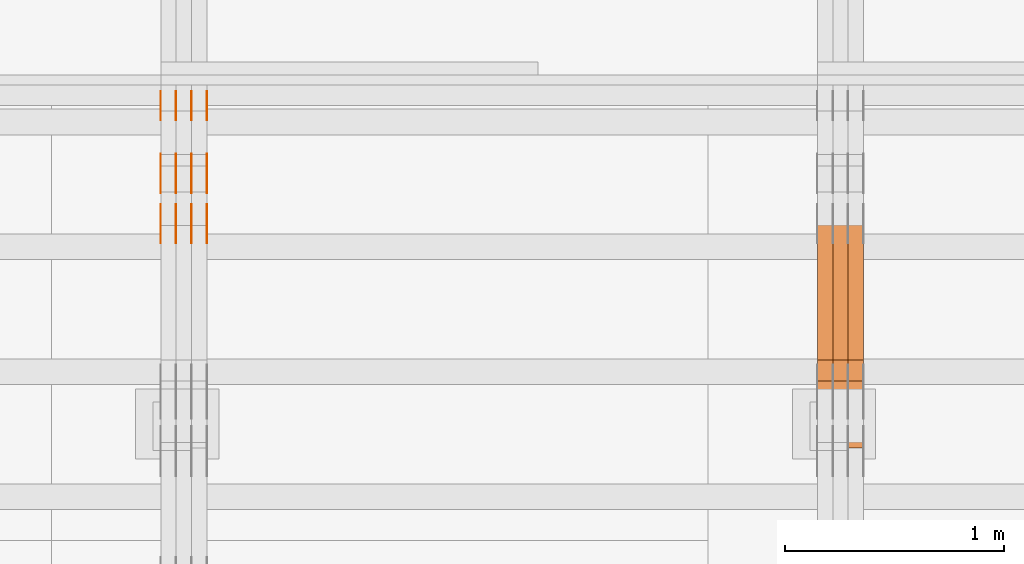
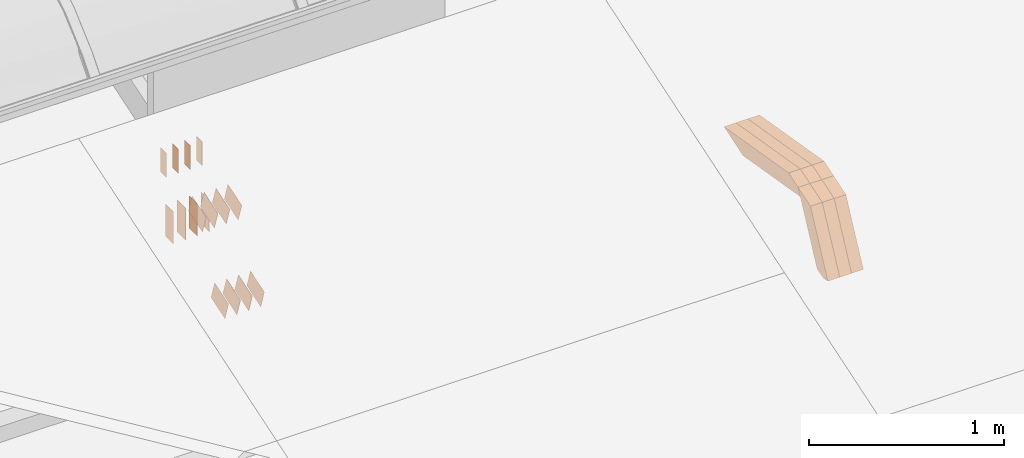
# One storey, part 96 of 385: 30 proxies.
"""IFC2X3 building model written with IfcOpenShell, lengths in millimetres."""

import ifcopenshell
import ifcopenshell.guid

model = None  # the IFC model being written
_history = None  # IfcOwnerHistory: only IFC2X3 demands one
_inside = {}  # id of a spatial element -> (the spatial element, [elements in it])
_under = {}  # id of a project, library or spatial element -> (it, [spatial elements below it])
_declared = {}  # id of a project -> (the project, [libraries it declares])
_typed = {}  # id of a type object -> (the type object, [elements of that type])
_made_of = {}  # id of a material, layer set ... -> (it, [elements and type objects made of it])


def new_model(schema):
    """Start an empty IFC model of exactly this schema.

    Asked for "IFC4X3", IfcOpenShell would pick the latest addendum, in which some entities
    have other attributes; the version numbers below select the first issue.
    IFC2X3 requires an IfcOwnerHistory on every rooted entity: one is made here for all.
    """
    global model, _history
    if schema == "IFC4X3":
        model = ifcopenshell.file(schema_version=(4, 3, 0, 0))
    else:
        model = ifcopenshell.file(schema=schema)
    _inside.clear()
    _under.clear()
    _declared.clear()
    _typed.clear()
    _made_of.clear()
    _history = None
    if model.schema == "IFC2X3":
        org = make("IfcOrganization", Name="unknown")
        user = make(
            "IfcPersonAndOrganization",
            ThePerson=make("IfcPerson", FamilyName="unknown"),
            TheOrganization=org,
        )
        app = make(
            "IfcApplication",
            ApplicationDeveloper=org,
            Version="unknown",
            ApplicationFullName="unknown",
            ApplicationIdentifier="unknown",
        )
        _history = make(
            "IfcOwnerHistory",
            OwningUser=user,
            OwningApplication=app,
            ChangeAction="ADDED",
            CreationDate=0,
        )
    return model


def make(cls, **values):
    """One entity of the class cls with the attributes given. An attribute that is None is left unset."""
    return model.create_entity(
        cls, **{name: value for name, value in values.items() if value is not None}
    )


def entity(cls, *values):
    """Any entity or typed value of the class cls, its attributes in the order of the schema. None: left unset."""
    e = model.create_entity(cls)
    for i, value in enumerate(values):
        if value is not None:
            e[i] = value
    return e


def rooted(cls, **values):
    """An entity with a GlobalId (a new one), such as an element, a storey or a relation."""
    return make(cls, GlobalId=ifcopenshell.guid.new(), OwnerHistory=_history, **values)


def si_unit(unit_type, name, prefix=None):
    """IfcSIUnit, for example si_unit("LENGTHUNIT", "METRE", prefix="MILLI")."""
    return make("IfcSIUnit", UnitType=unit_type, Prefix=prefix, Name=name)


def converted_unit(unit_type, name, factor, base, dimensions=None, offset=None):
    """IfcConversionBasedUnit, such as the inch: factor (a typed value) times the base unit."""
    return make(
        "IfcConversionBasedUnit"
        if offset is None
        else "IfcConversionBasedUnitWithOffset",
        ConversionOffset=offset,
        Dimensions=None
        if dimensions is None
        else entity("IfcDimensionalExponents", *dimensions),
        UnitType=unit_type,
        Name=name,
        ConversionFactor=make(
            "IfcMeasureWithUnit", ValueComponent=factor, UnitComponent=base
        ),
    )


def derived_unit(unit_type, elements):
    """IfcDerivedUnit: a product of units, each with its exponent."""
    return make(
        "IfcDerivedUnit",
        Elements=[
            make("IfcDerivedUnitElement", Unit=unit, Exponent=power)
            for unit, power in elements
        ],
        UnitType=unit_type,
    )


def assignment(units):
    """IfcUnitAssignment: the units of a project."""
    return None if units is None else make("IfcUnitAssignment", Units=units)


def point(xyz):
    """IfcCartesianPoint."""
    return None if xyz is None else make("IfcCartesianPoint", Coordinates=xyz)


def direction(xyz):
    """IfcDirection."""
    return None if xyz is None else make("IfcDirection", DirectionRatios=xyz)


def frame(location, z_axis=None, x_axis=None):
    """IfcAxis2Placement3D, a coordinate frame: its origin and axes. An axis left out is left unset."""
    return make(
        "IfcAxis2Placement3D",
        Location=point(location),
        Axis=direction(z_axis),
        RefDirection=direction(x_axis),
    )


def frame_2d(location, x_axis=None):
    """IfcAxis2Placement2D, a coordinate frame in the plane: its origin and x axis."""
    return make(
        "IfcAxis2Placement2D", Location=point(location), RefDirection=direction(x_axis)
    )


def origin():
    """The frame at (0, 0, 0) with its axes left unset."""
    return frame((0.0, 0.0, 0.0))


def origin_2d_with_axis():
    """The frame at (0, 0) in the plane with the x axis (1, 0) written out."""
    return frame_2d((0.0, 0.0), x_axis=(1.0, 0.0))


def place(relative_to, where):
    """IfcLocalPlacement: puts the frame where relative to a parent placement (None: the world)."""
    return make(
        "IfcLocalPlacement", PlacementRelTo=relative_to, RelativePlacement=where
    )


def context(
    kind, dimensions, precision=None, world=None, true_north=None, identifier=None
):
    """IfcGeometricRepresentationContext, for example the 3D "Model" context."""
    return make(
        "IfcGeometricRepresentationContext",
        ContextIdentifier=identifier,
        ContextType=kind,
        CoordinateSpaceDimension=dimensions,
        Precision=precision,
        WorldCoordinateSystem=world,
        TrueNorth=true_north,
    )


def subcontext(parent, identifier, kind, view, scale=None):
    """IfcGeometricRepresentationSubContext, for example "Body" below "Model"."""
    return make(
        "IfcGeometricRepresentationSubContext",
        ContextIdentifier=identifier,
        ContextType=kind,
        ParentContext=parent,
        TargetScale=scale,
        TargetView=view,
    )


def project(units=None, contexts=None):
    """IfcProject with its units and contexts."""
    return rooted(
        "IfcProject",
        Name="project",
        RepresentationContexts=contexts,
        UnitsInContext=assignment(units),
    )


def spatial(cls, under=None, at=None, **own):
    """A site, building, storey or space (cls), placed at a placement, below another one or the project."""
    s = rooted(cls, ObjectPlacement=at, **own)
    if under is not None:
        _under.setdefault(under.id(), (under, []))[1].append(s)
    return s


def polyline(points):
    """IfcPolyline through the points."""
    return make("IfcPolyline", Points=[point(p) for p in points])


def profile(cls, at=None, kind="AREA", **sizes):
    """A parametric profile (cls). Its sizes go by their IFC names, for example OverallWidth=200.0."""
    return make(cls, ProfileType=kind, Position=at, **sizes)


def rectangle(**sizes):
    """IfcRectangleProfileDef."""
    return profile("IfcRectangleProfileDef", **sizes)


def outline(outer, holes=None, kind="AREA"):
    """IfcArbitraryClosedProfileDef: a profile drawn as a closed curve; with holes, ...WithVoids."""
    if holes is None:
        return make("IfcArbitraryClosedProfileDef", ProfileType=kind, OuterCurve=outer)
    return make(
        "IfcArbitraryProfileDefWithVoids",
        ProfileType=kind,
        OuterCurve=outer,
        InnerCurves=holes,
    )


def extrude(swept, where, along, depth):
    """IfcExtrudedAreaSolid: the profile swept, set in the frame where, extruded along a direction by depth."""
    return make(
        "IfcExtrudedAreaSolid",
        SweptArea=swept,
        Position=where,
        ExtrudedDirection=direction(along),
        Depth=depth,
    )


def shape(context_of_items, identifier, shape_type, items):
    """IfcShapeRepresentation: the items that make up one representation, for example the "Body"."""
    return make(
        "IfcShapeRepresentation",
        ContextOfItems=context_of_items,
        RepresentationIdentifier=identifier,
        RepresentationType=shape_type,
        Items=items,
    )


def source(mapping_origin, context_of_items, identifier, shape_type, items):
    """IfcRepresentationMap: a shape defined once, which mapped items show again and again."""
    return make(
        "IfcRepresentationMap",
        MappingOrigin=mapping_origin,
        MappedRepresentation=shape(context_of_items, identifier, shape_type, items),
    )


def transform(
    local_origin,
    x_axis=None,
    y_axis=None,
    z_axis=None,
    scale=None,
    scale2=None,
    scale3=None,
    uniform=True,
):
    """IfcCartesianTransformationOperator3D, or its non-uniform kind. x_axis, y_axis, z_axis: its Axis1, 2, 3."""
    if uniform:
        return make(
            "IfcCartesianTransformationOperator3D",
            Axis1=direction(x_axis),
            Axis2=direction(y_axis),
            LocalOrigin=point(local_origin),
            Scale=scale,
            Axis3=direction(z_axis),
        )
    return make(
        "IfcCartesianTransformationOperator3DnonUniform",
        Axis1=direction(x_axis),
        Axis2=direction(y_axis),
        LocalOrigin=point(local_origin),
        Scale=scale,
        Axis3=direction(z_axis),
        Scale2=scale2,
        Scale3=scale3,
    )


def mapped(mapping_source, mapping_target):
    """IfcMappedItem: shows the shape of a source again, moved by a transform."""
    return make(
        "IfcMappedItem", MappingSource=mapping_source, MappingTarget=mapping_target
    )


def material(Name=None, Category=None):
    """IfcMaterial."""
    return make("IfcMaterial", Name=Name, Category=Category)


def made_of(thing, what):
    """Note that an element or type object is made of a material, layer set ...; save() writes the relation."""
    if what is not None:
        _made_of.setdefault(what.id(), (what, []))[1].append(thing)
    return thing


def type_object(cls, material=None, **own):
    """A type object (cls), such as IfcWallType, which elements share."""
    return made_of(rooted(cls, **own), material)


def type_shapes(of_type, sources):
    """Give a type object the sources (RepresentationMaps) that its elements show as mapped items."""
    of_type.RepresentationMaps = sources


def element(
    cls,
    number,
    at=None,
    inside=None,
    cuts=None,
    type_object=None,
    material=None,
    context=None,
    identifier="Body",
    shape_type=None,
    held_by="IfcProductDefinitionShape",
    body=None,
    shapes=None,
    **own,
):
    """One element of the class cls, such as IfcWall. Its Tag is "e" and its number.

    at: its placement. inside: the storey or other place that contains it. cuts: it is an
    opening in that element (IfcRelVoidsElement). A single representation is given by context,
    identifier, shape_type and body (its items); several are given by shapes. held_by: the class
    of the entity that holds the representations. save() writes the other relations.
    """
    e = rooted(cls, Tag="e%d" % number, ObjectPlacement=at, **own)
    if body is not None:
        shapes = [shape(context, identifier, shape_type, body)]
    if shapes is not None:
        e.Representation = make(held_by, Representations=shapes)
    if inside is not None:
        _inside.setdefault(inside.id(), (inside, []))[1].append(e)
    if cuts is not None:
        rooted(
            "IfcRelVoidsElement", RelatingBuildingElement=cuts, RelatedOpeningElement=e
        )
    if type_object is not None:
        _typed.setdefault(type_object.id(), (type_object, []))[1].append(e)
    return made_of(e, material)


def aggregate(whole, parts):
    """IfcRelAggregates: a whole, such as a stair, and the parts it consists of."""
    return rooted("IfcRelAggregates", RelatingObject=whole, RelatedObjects=parts)


def save(model, path):
    """Write the relations noted so far, then the file.

    IfcRelAggregates (storeys below a building ...), IfcRelContainedInSpatialStructure (elements
    in a storey), IfcRelDefinesByType, IfcRelAssociatesMaterial and IfcRelDeclares: one each for
    every whole, place, type object, material and project.
    """
    for whole, parts in _under.values():
        aggregate(whole, parts)
    for where, things in _inside.values():
        rooted(
            "IfcRelContainedInSpatialStructure",
            RelatedElements=things,
            RelatingStructure=where,
        )
    for kind, things in _typed.values():
        rooted("IfcRelDefinesByType", RelatedObjects=things, RelatingType=kind)
    for what, things in _made_of.values():
        rooted("IfcRelAssociatesMaterial", RelatedObjects=things, RelatingMaterial=what)
    for by, libraries in _declared.values():
        rooted("IfcRelDeclares", RelatingContext=by, RelatedDefinitions=libraries)
    model.write(path)


model = new_model("IFC2X3")

# Units and contexts
model_context = context("Model", 3, precision=0.01, world=origin(), true_north=direction((6.12303176911189e-17, 1.0)))
body_context = subcontext(model_context, "Body", "Model", "MODEL_VIEW")
ifc_project = project(units=[si_unit("LENGTHUNIT", "METRE", prefix="MILLI"), si_unit("AREAUNIT", "SQUARE_METRE"), si_unit("VOLUMEUNIT", "CUBIC_METRE"), converted_unit("PLANEANGLEUNIT", "DEGREE", entity("IfcRatioMeasure", 0.0174532925199433), si_unit("PLANEANGLEUNIT", "RADIAN"), dimensions=[0, 0, 0, 0, 0, 0, 0]), si_unit("MASSUNIT", "GRAM", prefix="KILO"), derived_unit("MASSDENSITYUNIT", [(si_unit("MASSUNIT", "GRAM", prefix="KILO"), 1), (si_unit("LENGTHUNIT", "METRE"), -3)]), si_unit("TIMEUNIT", "SECOND"), si_unit("FREQUENCYUNIT", "HERTZ"), si_unit("THERMODYNAMICTEMPERATUREUNIT", "DEGREE_CELSIUS"), derived_unit("THERMALTRANSMITTANCEUNIT", [(si_unit("MASSUNIT", "GRAM", prefix="KILO"), 1), (si_unit("THERMODYNAMICTEMPERATUREUNIT", "KELVIN"), -1), (si_unit("TIMEUNIT", "SECOND"), -3)]), derived_unit("VOLUMETRICFLOWRATEUNIT", [(si_unit("LENGTHUNIT", "METRE"), 3), (si_unit("TIMEUNIT", "SECOND"), -1)]), si_unit("ELECTRICCURRENTUNIT", "AMPERE"), si_unit("ELECTRICVOLTAGEUNIT", "VOLT"), si_unit("POWERUNIT", "WATT"), si_unit("FORCEUNIT", "NEWTON", prefix="KILO"), si_unit("ILLUMINANCEUNIT", "LUX"), si_unit("LUMINOUSFLUXUNIT", "LUMEN"), si_unit("LUMINOUSINTENSITYUNIT", "CANDELA"), derived_unit("USERDEFINED", [(si_unit("MASSUNIT", "GRAM", prefix="KILO"), -1), (si_unit("LENGTHUNIT", "METRE"), -2), (si_unit("TIMEUNIT", "SECOND"), 3), (si_unit("LUMINOUSFLUXUNIT", "LUMEN"), 1)]), derived_unit("LINEARVELOCITYUNIT", [(si_unit("LENGTHUNIT", "METRE"), 1), (si_unit("TIMEUNIT", "SECOND"), -1)]), si_unit("PRESSUREUNIT", "PASCAL"), derived_unit("USERDEFINED", [(si_unit("LENGTHUNIT", "METRE"), -2), (si_unit("MASSUNIT", "GRAM", prefix="KILO"), 1), (si_unit("TIMEUNIT", "SECOND"), -2)])], contexts=[model_context])

# Site, building, storey
site_placement = place(None, origin())
site = spatial("IfcSite", under=ifc_project, at=site_placement, CompositionType="ELEMENT")
building_placement = place(site_placement, origin())
building = spatial("IfcBuilding", under=site, at=building_placement, CompositionType="ELEMENT")
storey_placement = place(building_placement, origin())
storey = spatial("IfcBuildingStorey", under=building, at=storey_placement, Name="Default", CompositionType="ELEMENT", Elevation=0.0)

# Proxies
ifc_material_1 = material(Name="IfcSurfaceStyle #189376")
building_element_proxy_type_1 = type_object("IfcBuildingElementProxyType", Name="T1-W7 189374", PredefinedType="NOTDEFINED", material=ifc_material_1)
shared_shape_1 = source(origin(), body_context, "Body", "SweptSolid", [
    extrude(outline(polyline([(-296.174043820986, -47.5000676566704), (297.841254477443, -47.5000676566704), (283.518570346415, -7.10254316533821e-06), (192.674144473719, 47.500071207942), (-477.859925476591, 47.500071207942), (-296.174043820986, -47.5000676566704)])), frame((297.841254477443, 47.5000816097442, 0.0), z_axis=(0.0, 0.0, 1.0), x_axis=(-1.0, 0.0, 0.0)), (0.0, 0.0, 1.0), 70.0),
])
type_shapes(building_element_proxy_type_1, [shared_shape_1])
proxy_1_placement = place(building_placement, frame((15385.0, 12419.2991208897, 3526.2136755972), z_axis=(-1.0, 0.0, 0.0), x_axis=(0.0, 0.985983815111804, -0.166840991178939)))
element("IfcBuildingElementProxy", 1, at=proxy_1_placement, inside=storey, type_object=building_element_proxy_type_1, material=ifc_material_1, Name="T1-W7", context=body_context, shape_type="MappedRepresentation", body=[
    mapped(shared_shape_1, transform((0.0, 0.0, 0.0), scale=1.0)),
])
ifc_material_2 = material(Name="IfcSurfaceStyle #189310")
building_element_proxy_type_2 = type_object("IfcBuildingElementProxyType", Name="T1-W7 189308", PredefinedType="NOTDEFINED", material=ifc_material_2)
shared_shape_2 = source(origin(), body_context, "Body", "SweptSolid", [
    extrude(outline(polyline([(-296.174043820986, -47.5000676566704), (297.841254477443, -47.5000676566704), (283.518570346415, -7.10254316533821e-06), (192.674144473719, 47.500071207942), (-477.859925476591, 47.500071207942), (-296.174043820986, -47.5000676566704)])), frame((297.841254477443, 47.5000816097442, 0.0), z_axis=(0.0, 0.0, 1.0), x_axis=(-1.0, 0.0, 0.0)), (0.0, 0.0, 1.0), 70.0),
])
type_shapes(building_element_proxy_type_2, [shared_shape_2])
proxy_2_placement = place(building_placement, frame((15315.0, 12419.2991208897, 3526.2136755972), z_axis=(-1.0, 0.0, 0.0), x_axis=(0.0, 0.985983815111804, -0.166840991178939)))
element("IfcBuildingElementProxy", 2, at=proxy_2_placement, inside=storey, type_object=building_element_proxy_type_2, material=ifc_material_2, Name="T1-W7", context=body_context, shape_type="MappedRepresentation", body=[
    mapped(shared_shape_2, transform((0.0, 0.0, 0.0), scale=1.0)),
])
ifc_material_3 = material(Name="IfcSurfaceStyle #189244")
building_element_proxy_type_3 = type_object("IfcBuildingElementProxyType", Name="T1-W7 189242", PredefinedType="NOTDEFINED", material=ifc_material_3)
shared_shape_3 = source(origin(), body_context, "Body", "SweptSolid", [
    extrude(outline(polyline([(-296.174043820986, -47.5000676566704), (297.841254477443, -47.5000676566704), (283.518570346415, -7.10254316533821e-06), (192.674144473719, 47.500071207942), (-477.859925476591, 47.500071207942), (-296.174043820986, -47.5000676566704)])), frame((297.841254477443, 47.5000816097442, 0.0), z_axis=(0.0, 0.0, 1.0), x_axis=(-1.0, 0.0, 0.0)), (0.0, 0.0, 1.0), 70.0),
])
type_shapes(building_element_proxy_type_3, [shared_shape_3])
proxy_3_placement = place(building_placement, frame((15245.0, 12419.2991208897, 3526.2136755972), z_axis=(-1.0, 0.0, 0.0), x_axis=(0.0, 0.985983815111804, -0.166840991178939)))
element("IfcBuildingElementProxy", 3, at=proxy_3_placement, inside=storey, type_object=building_element_proxy_type_3, material=ifc_material_3, Name="T1-W7", context=body_context, shape_type="MappedRepresentation", body=[
    mapped(shared_shape_3, transform((0.0, 0.0, 0.0), scale=1.0)),
])
ifc_material_4 = material(Name="IfcSurfaceStyle #188980")
building_element_proxy_type_4 = type_object("IfcBuildingElementProxyType", Name="T1-W36 188978", PredefinedType="NOTDEFINED", material=ifc_material_4)
shared_shape_4 = source(origin(), body_context, "Body", "SweptSolid", [
    extrude(outline(polyline([(-300.714670922549, -47.4998881108849), (134.031527004269, -47.499888110885), (180.52054953879, -0.000136170977331764), (193.89900152221, 47.500563476126), (-207.736407142719, 47.4993489166213), (-300.714670922549, -47.4998881108849)])), frame((193.899145164686, 47.5001861375837, 0.0), z_axis=(0.0, 0.0, 1.0), x_axis=(-1.0, 3.02403492980632e-06, 0.0)), (0.0, 0.0, 1.0), 70.0),
])
type_shapes(building_element_proxy_type_4, [shared_shape_4])
proxy_4_placement = place(building_placement, frame((15385.0, 12120.5935627532, 3076.1128858536), z_axis=(-1.0, 0.0, 0.0), x_axis=(0.0, 0.444384650266842, 0.895836080210669)))
element("IfcBuildingElementProxy", 4, at=proxy_4_placement, inside=storey, type_object=building_element_proxy_type_4, material=ifc_material_4, Name="T1-W36", context=body_context, shape_type="MappedRepresentation", body=[
    mapped(shared_shape_4, transform((0.0, 0.0, 0.0), scale=1.0)),
])
ifc_material_5 = material(Name="IfcSurfaceStyle #188914")
building_element_proxy_type_5 = type_object("IfcBuildingElementProxyType", Name="T1-W36 188912", PredefinedType="NOTDEFINED", material=ifc_material_5)
shared_shape_5 = source(origin(), body_context, "Body", "SweptSolid", [
    extrude(outline(polyline([(-300.714670922549, -47.4998881108849), (134.031527004269, -47.499888110885), (180.52054953879, -0.000136170977331764), (193.89900152221, 47.500563476126), (-207.736407142719, 47.4993489166213), (-300.714670922549, -47.4998881108849)])), frame((193.899145164686, 47.5001861375837, 0.0), z_axis=(0.0, 0.0, 1.0), x_axis=(-1.0, 3.02403492980632e-06, 0.0)), (0.0, 0.0, 1.0), 70.0),
])
type_shapes(building_element_proxy_type_5, [shared_shape_5])
proxy_5_placement = place(building_placement, frame((15315.0, 12120.5935627532, 3076.1128858536), z_axis=(-1.0, 0.0, 0.0), x_axis=(0.0, 0.444384650266842, 0.895836080210669)))
element("IfcBuildingElementProxy", 5, at=proxy_5_placement, inside=storey, type_object=building_element_proxy_type_5, material=ifc_material_5, Name="T1-W36", context=body_context, shape_type="MappedRepresentation", body=[
    mapped(shared_shape_5, transform((0.0, 0.0, 0.0), scale=1.0)),
])
ifc_material_6 = material(Name="IfcSurfaceStyle #188848")
building_element_proxy_type_6 = type_object("IfcBuildingElementProxyType", Name="T1-W36 188846", PredefinedType="NOTDEFINED", material=ifc_material_6)
shared_shape_6 = source(origin(), body_context, "Body", "SweptSolid", [
    extrude(outline(polyline([(-300.714670922549, -47.4998881108849), (134.031527004269, -47.499888110885), (180.52054953879, -0.000136170977331764), (193.89900152221, 47.500563476126), (-207.736407142719, 47.4993489166213), (-300.714670922549, -47.4998881108849)])), frame((193.899145164686, 47.5001861375837, 0.0), z_axis=(0.0, 0.0, 1.0), x_axis=(-1.0, 3.02403492980632e-06, 0.0)), (0.0, 0.0, 1.0), 70.0),
])
type_shapes(building_element_proxy_type_6, [shared_shape_6])
proxy_6_placement = place(building_placement, frame((15245.0, 12120.5935627532, 3076.1128858536), z_axis=(-1.0, 0.0, 0.0), x_axis=(0.0, 0.444384650266842, 0.895836080210669)))
element("IfcBuildingElementProxy", 6, at=proxy_6_placement, inside=storey, type_object=building_element_proxy_type_6, material=ifc_material_6, Name="T1-W36", context=body_context, shape_type="MappedRepresentation", body=[
    mapped(shared_shape_6, transform((0.0, 0.0, 0.0), scale=1.0)),
])
ifc_material_7 = material(Name="IfcSurfaceStyle #174708")
building_element_proxy_type_7 = type_object("IfcBuildingElementProxyType", PredefinedType="NOTDEFINED", material=ifc_material_7)
shared_shape_7 = source(origin(), body_context, "Body", "SweptSolid", [
    extrude(rectangle(XDim=200.0, YDim=84.0, at=frame_2d((0.0, -7.105427357601e-15), x_axis=(1.0, 0.0))), frame((100.0, 42.0, 0.0), z_axis=(0.0, 0.0, 1.0), x_axis=(-1.0, 0.0, 0.0)), (0.0, 0.0, 1.0), 1.3),
])
type_shapes(building_element_proxy_type_7, [shared_shape_7])
proxy_7_placement = place(building_placement, frame((12386.3, 13702.0, 3651.4150390625), z_axis=(-1.0, 0.0, 0.0), x_axis=(0.0, 0.0, -1.0)))
element("IfcBuildingElementProxy", 7, at=proxy_7_placement, inside=storey, type_object=building_element_proxy_type_7, material=ifc_material_7, context=body_context, shape_type="MappedRepresentation", body=[
    mapped(shared_shape_7, transform((0.0, 0.0, 0.0), scale=1.0)),
])
ifc_material_8 = material(Name="IfcSurfaceStyle #174651")
building_element_proxy_type_8 = type_object("IfcBuildingElementProxyType", PredefinedType="NOTDEFINED", material=ifc_material_8)
shared_shape_8 = source(origin(), body_context, "Body", "SweptSolid", [
    extrude(rectangle(XDim=200.0, YDim=84.0, at=frame_2d((0.0, -7.105427357601e-15), x_axis=(1.0, 0.0))), frame((100.0, 42.0, 0.0), z_axis=(0.0, 0.0, 1.0), x_axis=(-1.0, 0.0, 0.0)), (0.0, 0.0, 1.0), 1.3),
])
type_shapes(building_element_proxy_type_8, [shared_shape_8])
proxy_8_placement = place(building_placement, frame((12315.0, 13702.0, 3651.4150390625), z_axis=(-1.0, 0.0, 0.0), x_axis=(0.0, 0.0, -1.0)))
element("IfcBuildingElementProxy", 8, at=proxy_8_placement, inside=storey, type_object=building_element_proxy_type_8, material=ifc_material_8, context=body_context, shape_type="MappedRepresentation", body=[
    mapped(shared_shape_8, transform((0.0, 0.0, 0.0), scale=1.0)),
])
ifc_material_9 = material(Name="IfcSurfaceStyle #174594")
building_element_proxy_type_9 = type_object("IfcBuildingElementProxyType", PredefinedType="NOTDEFINED", material=ifc_material_9)
shared_shape_9 = source(origin(), body_context, "Body", "SweptSolid", [
    extrude(rectangle(XDim=200.0, YDim=84.0, at=frame_2d((0.0, -7.105427357601e-15), x_axis=(1.0, 0.0))), frame((100.0, 42.0, 0.0), z_axis=(0.0, 0.0, 1.0), x_axis=(-1.0, 0.0, 0.0)), (0.0, 0.0, 1.0), 1.3),
])
type_shapes(building_element_proxy_type_9, [shared_shape_9])
proxy_9_placement = place(building_placement, frame((12316.3, 13702.0, 3651.4150390625), z_axis=(-1.0, 0.0, 0.0), x_axis=(0.0, 0.0, -1.0)))
element("IfcBuildingElementProxy", 9, at=proxy_9_placement, inside=storey, type_object=building_element_proxy_type_9, material=ifc_material_9, context=body_context, shape_type="MappedRepresentation", body=[
    mapped(shared_shape_9, transform((0.0, 0.0, 0.0), scale=1.0)),
])
ifc_material_10 = material(Name="IfcSurfaceStyle #174537")
building_element_proxy_type_10 = type_object("IfcBuildingElementProxyType", PredefinedType="NOTDEFINED", material=ifc_material_10)
shared_shape_10 = source(origin(), body_context, "Body", "SweptSolid", [
    extrude(rectangle(XDim=200.0, YDim=84.0, at=frame_2d((0.0, -7.105427357601e-15), x_axis=(1.0, 0.0))), frame((100.0, 42.0, 0.0), z_axis=(0.0, 0.0, 1.0), x_axis=(-1.0, 0.0, 0.0)), (0.0, 0.0, 1.0), 1.29999999999998),
])
type_shapes(building_element_proxy_type_10, [shared_shape_10])
proxy_10_placement = place(building_placement, frame((12245.0, 13702.0, 3651.4150390625), z_axis=(-1.0, 0.0, 0.0), x_axis=(0.0, 0.0, -1.0)))
element("IfcBuildingElementProxy", 10, at=proxy_10_placement, inside=storey, type_object=building_element_proxy_type_10, material=ifc_material_10, context=body_context, shape_type="MappedRepresentation", body=[
    mapped(shared_shape_10, transform((0.0, 0.0, 0.0), scale=1.0)),
])
ifc_material_11 = material(Name="IfcSurfaceStyle #174480")
building_element_proxy_type_11 = type_object("IfcBuildingElementProxyType", PredefinedType="NOTDEFINED", material=ifc_material_11)
shared_shape_11 = source(origin(), body_context, "Body", "SweptSolid", [
    extrude(rectangle(XDim=200.0, YDim=84.0, at=frame_2d((0.0, -7.105427357601e-15), x_axis=(1.0, 0.0))), frame((100.0, 42.0, 0.0), z_axis=(0.0, 0.0, 1.0), x_axis=(-1.0, 0.0, 0.0)), (0.0, 0.0, 1.0), 1.29999999999998),
])
type_shapes(building_element_proxy_type_11, [shared_shape_11])
proxy_11_placement = place(building_placement, frame((12246.3, 13702.0, 3651.4150390625), z_axis=(-1.0, 0.0, 0.0), x_axis=(0.0, 0.0, -1.0)))
element("IfcBuildingElementProxy", 11, at=proxy_11_placement, inside=storey, type_object=building_element_proxy_type_11, material=ifc_material_11, context=body_context, shape_type="MappedRepresentation", body=[
    mapped(shared_shape_11, transform((0.0, 0.0, 0.0), scale=1.0)),
])
ifc_material_12 = material(Name="IfcSurfaceStyle #174423")
building_element_proxy_type_12 = type_object("IfcBuildingElementProxyType", PredefinedType="NOTDEFINED", material=ifc_material_12)
shared_shape_12 = source(origin(), body_context, "Body", "SweptSolid", [
    extrude(rectangle(XDim=200.0, YDim=84.0, at=frame_2d((0.0, -7.105427357601e-15), x_axis=(1.0, 0.0))), frame((100.0, 42.0, 0.0), z_axis=(0.0, 0.0, 1.0), x_axis=(-1.0, 0.0, 0.0)), (0.0, 0.0, 1.0), 1.29999999999999),
])
type_shapes(building_element_proxy_type_12, [shared_shape_12])
proxy_12_placement = place(building_placement, frame((12175.0, 13702.0, 3651.4150390625), z_axis=(-1.0, 0.0, 0.0), x_axis=(0.0, 0.0, -1.0)))
element("IfcBuildingElementProxy", 12, at=proxy_12_placement, inside=storey, type_object=building_element_proxy_type_12, material=ifc_material_12, context=body_context, shape_type="MappedRepresentation", body=[
    mapped(shared_shape_12, transform((0.0, 0.0, 0.0), scale=1.0)),
])
ifc_material_13 = material(Name="IfcSurfaceStyle #174366")
building_element_proxy_type_13 = type_object("IfcBuildingElementProxyType", PredefinedType="NOTDEFINED", material=ifc_material_13)
shared_shape_13 = source(origin(), body_context, "Body", "SweptSolid", [
    extrude(outline(polyline([(-75.0003398116828, -59.9998507501386), (75.0003249421766, -59.9998507501386), (75.0003398116837, 59.9998507501387), (-75.0003249421775, 59.9998507501387), (-75.0003398116828, -59.9998507501386)])), frame((75.0003398116837, 60.0000773549637, 0.0), z_axis=(0.0, 0.0, 1.0), x_axis=(-1.0, 0.0, 0.0)), (0.0, 0.0, 1.0), 1.3),
])
type_shapes(building_element_proxy_type_13, [shared_shape_13])
proxy_13_placement = place(building_placement, frame((12386.3, 13054.73046875, 3417.8388671875), z_axis=(-1.0, 0.0, 0.0), x_axis=(0.0, 0.951056516295124, 0.309016994375039)))
element("IfcBuildingElementProxy", 13, at=proxy_13_placement, inside=storey, type_object=building_element_proxy_type_13, material=ifc_material_13, context=body_context, shape_type="MappedRepresentation", body=[
    mapped(shared_shape_13, transform((0.0, 0.0, 0.0), scale=1.0)),
])
ifc_material_14 = material(Name="IfcSurfaceStyle #174309")
building_element_proxy_type_14 = type_object("IfcBuildingElementProxyType", PredefinedType="NOTDEFINED", material=ifc_material_14)
shared_shape_14 = source(origin(), body_context, "Body", "SweptSolid", [
    extrude(outline(polyline([(-75.0003398116828, -59.9998507501386), (75.0003249421766, -59.9998507501386), (75.0003398116837, 59.9998507501387), (-75.0003249421775, 59.9998507501387), (-75.0003398116828, -59.9998507501386)])), frame((75.0003398116837, 60.0000773549637, 0.0), z_axis=(0.0, 0.0, 1.0), x_axis=(-1.0, 0.0, 0.0)), (0.0, 0.0, 1.0), 1.3),
])
type_shapes(building_element_proxy_type_14, [shared_shape_14])
proxy_14_placement = place(building_placement, frame((12315.0, 13054.73046875, 3417.8388671875), z_axis=(-1.0, 0.0, 0.0), x_axis=(0.0, 0.951056516295124, 0.309016994375039)))
element("IfcBuildingElementProxy", 14, at=proxy_14_placement, inside=storey, type_object=building_element_proxy_type_14, material=ifc_material_14, context=body_context, shape_type="MappedRepresentation", body=[
    mapped(shared_shape_14, transform((0.0, 0.0, 0.0), scale=1.0)),
])
ifc_material_15 = material(Name="IfcSurfaceStyle #174252")
building_element_proxy_type_15 = type_object("IfcBuildingElementProxyType", PredefinedType="NOTDEFINED", material=ifc_material_15)
shared_shape_15 = source(origin(), body_context, "Body", "SweptSolid", [
    extrude(outline(polyline([(-75.0003398116828, -59.9998507501386), (75.0003249421766, -59.9998507501386), (75.0003398116837, 59.9998507501387), (-75.0003249421775, 59.9998507501387), (-75.0003398116828, -59.9998507501386)])), frame((75.0003398116837, 60.0000773549637, 0.0), z_axis=(0.0, 0.0, 1.0), x_axis=(-1.0, 0.0, 0.0)), (0.0, 0.0, 1.0), 1.3),
])
type_shapes(building_element_proxy_type_15, [shared_shape_15])
proxy_15_placement = place(building_placement, frame((12316.3, 13054.73046875, 3417.8388671875), z_axis=(-1.0, 0.0, 0.0), x_axis=(0.0, 0.951056516295124, 0.309016994375039)))
element("IfcBuildingElementProxy", 15, at=proxy_15_placement, inside=storey, type_object=building_element_proxy_type_15, material=ifc_material_15, context=body_context, shape_type="MappedRepresentation", body=[
    mapped(shared_shape_15, transform((0.0, 0.0, 0.0), scale=1.0)),
])
ifc_material_16 = material(Name="IfcSurfaceStyle #174195")
building_element_proxy_type_16 = type_object("IfcBuildingElementProxyType", PredefinedType="NOTDEFINED", material=ifc_material_16)
shared_shape_16 = source(origin(), body_context, "Body", "SweptSolid", [
    extrude(outline(polyline([(-75.0003398116828, -59.9998507501386), (75.0003249421766, -59.9998507501386), (75.0003398116837, 59.9998507501387), (-75.0003249421775, 59.9998507501387), (-75.0003398116828, -59.9998507501386)])), frame((75.0003398116837, 60.0000773549637, 0.0), z_axis=(0.0, 0.0, 1.0), x_axis=(-1.0, 0.0, 0.0)), (0.0, 0.0, 1.0), 1.29999999999999),
])
type_shapes(building_element_proxy_type_16, [shared_shape_16])
proxy_16_placement = place(building_placement, frame((12245.0, 13054.73046875, 3417.8388671875), z_axis=(-1.0, 0.0, 0.0), x_axis=(0.0, 0.951056516295124, 0.309016994375039)))
element("IfcBuildingElementProxy", 16, at=proxy_16_placement, inside=storey, type_object=building_element_proxy_type_16, material=ifc_material_16, context=body_context, shape_type="MappedRepresentation", body=[
    mapped(shared_shape_16, transform((0.0, 0.0, 0.0), scale=1.0)),
])
ifc_material_17 = material(Name="IfcSurfaceStyle #174138")
building_element_proxy_type_17 = type_object("IfcBuildingElementProxyType", PredefinedType="NOTDEFINED", material=ifc_material_17)
shared_shape_17 = source(origin(), body_context, "Body", "SweptSolid", [
    extrude(outline(polyline([(-75.0003398116828, -59.9998507501386), (75.0003249421766, -59.9998507501386), (75.0003398116837, 59.9998507501387), (-75.0003249421775, 59.9998507501387), (-75.0003398116828, -59.9998507501386)])), frame((75.0003398116837, 60.0000773549637, 0.0), z_axis=(0.0, 0.0, 1.0), x_axis=(-1.0, 0.0, 0.0)), (0.0, 0.0, 1.0), 1.29999999999999),
])
type_shapes(building_element_proxy_type_17, [shared_shape_17])
proxy_17_placement = place(building_placement, frame((12246.3, 13054.73046875, 3417.8388671875), z_axis=(-1.0, 0.0, 0.0), x_axis=(0.0, 0.951056516295124, 0.309016994375039)))
element("IfcBuildingElementProxy", 17, at=proxy_17_placement, inside=storey, type_object=building_element_proxy_type_17, material=ifc_material_17, context=body_context, shape_type="MappedRepresentation", body=[
    mapped(shared_shape_17, transform((0.0, 0.0, 0.0), scale=1.0)),
])
ifc_material_18 = material(Name="IfcSurfaceStyle #174081")
building_element_proxy_type_18 = type_object("IfcBuildingElementProxyType", PredefinedType="NOTDEFINED", material=ifc_material_18)
shared_shape_18 = source(origin(), body_context, "Body", "SweptSolid", [
    extrude(outline(polyline([(-75.0003398116828, -59.9998507501386), (75.0003249421766, -59.9998507501386), (75.0003398116837, 59.9998507501387), (-75.0003249421775, 59.9998507501387), (-75.0003398116828, -59.9998507501386)])), frame((75.0003398116837, 60.0000773549637, 0.0), z_axis=(0.0, 0.0, 1.0), x_axis=(-1.0, 0.0, 0.0)), (0.0, 0.0, 1.0), 1.29999999999999),
])
type_shapes(building_element_proxy_type_18, [shared_shape_18])
proxy_18_placement = place(building_placement, frame((12175.0, 13054.73046875, 3417.8388671875), z_axis=(-1.0, 0.0, 0.0), x_axis=(0.0, 0.951056516295124, 0.309016994375039)))
element("IfcBuildingElementProxy", 18, at=proxy_18_placement, inside=storey, type_object=building_element_proxy_type_18, material=ifc_material_18, context=body_context, shape_type="MappedRepresentation", body=[
    mapped(shared_shape_18, transform((0.0, 0.0, 0.0), scale=1.0)),
])
ifc_material_19 = material(Name="IfcSurfaceStyle #166500")
building_element_proxy_type_19 = type_object("IfcBuildingElementProxyType", PredefinedType="NOTDEFINED", material=ifc_material_19)
shared_shape_19 = source(origin(), body_context, "Body", "SweptSolid", [
    extrude(outline(polyline([(-74.999875428623, -60.0000016373506), (74.9998605591059, -60.0000016373506), (74.9998754286239, 60.0000016373506), (-74.9998605591068, 60.0000016373506), (-74.999875428623, -60.0000016373506)])), frame((75.0002691827262, 60.0000190504561, 0.0), z_axis=(0.0, 0.0, 1.0), x_axis=(-1.0, 0.0, 0.0)), (0.0, 0.0, 1.0), 1.3),
])
type_shapes(building_element_proxy_type_19, [shared_shape_19])
proxy_19_placement = place(building_placement, frame((12386.3, 13285.0865109705, 3819.37496637467), z_axis=(-1.0, 0.0, 0.0), x_axis=(0.0, 0.951056516295154, 0.309016994374948)))
element("IfcBuildingElementProxy", 19, at=proxy_19_placement, inside=storey, type_object=building_element_proxy_type_19, material=ifc_material_19, context=body_context, shape_type="MappedRepresentation", body=[
    mapped(shared_shape_19, transform((0.0, 0.0, 0.0), scale=1.0)),
])
ifc_material_20 = material(Name="IfcSurfaceStyle #166443")
building_element_proxy_type_20 = type_object("IfcBuildingElementProxyType", PredefinedType="NOTDEFINED", material=ifc_material_20)
shared_shape_20 = source(origin(), body_context, "Body", "SweptSolid", [
    extrude(outline(polyline([(-74.999875428623, -60.0000016373506), (74.9998605591059, -60.0000016373506), (74.9998754286239, 60.0000016373506), (-74.9998605591068, 60.0000016373506), (-74.999875428623, -60.0000016373506)])), frame((75.0002691827262, 60.0000190504561, 0.0), z_axis=(0.0, 0.0, 1.0), x_axis=(-1.0, 0.0, 0.0)), (0.0, 0.0, 1.0), 1.3),
])
type_shapes(building_element_proxy_type_20, [shared_shape_20])
proxy_20_placement = place(building_placement, frame((12315.0, 13285.0865109705, 3819.37496637467), z_axis=(-1.0, 0.0, 0.0), x_axis=(0.0, 0.951056516295154, 0.309016994374948)))
element("IfcBuildingElementProxy", 20, at=proxy_20_placement, inside=storey, type_object=building_element_proxy_type_20, material=ifc_material_20, context=body_context, shape_type="MappedRepresentation", body=[
    mapped(shared_shape_20, transform((0.0, 0.0, 0.0), scale=1.0)),
])
ifc_material_21 = material(Name="IfcSurfaceStyle #166386")
building_element_proxy_type_21 = type_object("IfcBuildingElementProxyType", PredefinedType="NOTDEFINED", material=ifc_material_21)
shared_shape_21 = source(origin(), body_context, "Body", "SweptSolid", [
    extrude(outline(polyline([(-74.999875428623, -60.0000016373506), (74.9998605591059, -60.0000016373506), (74.9998754286239, 60.0000016373506), (-74.9998605591068, 60.0000016373506), (-74.999875428623, -60.0000016373506)])), frame((75.0002691827262, 60.0000190504561, 0.0), z_axis=(0.0, 0.0, 1.0), x_axis=(-1.0, 0.0, 0.0)), (0.0, 0.0, 1.0), 1.3),
])
type_shapes(building_element_proxy_type_21, [shared_shape_21])
proxy_21_placement = place(building_placement, frame((12316.3, 13285.0865109705, 3819.37496637467), z_axis=(-1.0, 0.0, 0.0), x_axis=(0.0, 0.951056516295154, 0.309016994374948)))
element("IfcBuildingElementProxy", 21, at=proxy_21_placement, inside=storey, type_object=building_element_proxy_type_21, material=ifc_material_21, context=body_context, shape_type="MappedRepresentation", body=[
    mapped(shared_shape_21, transform((0.0, 0.0, 0.0), scale=1.0)),
])
ifc_material_22 = material(Name="IfcSurfaceStyle #166329")
building_element_proxy_type_22 = type_object("IfcBuildingElementProxyType", PredefinedType="NOTDEFINED", material=ifc_material_22)
shared_shape_22 = source(origin(), body_context, "Body", "SweptSolid", [
    extrude(outline(polyline([(-74.999875428623, -60.0000016373506), (74.9998605591059, -60.0000016373506), (74.9998754286239, 60.0000016373506), (-74.9998605591068, 60.0000016373506), (-74.999875428623, -60.0000016373506)])), frame((75.0002691827262, 60.0000190504561, 0.0), z_axis=(0.0, 0.0, 1.0), x_axis=(-1.0, 0.0, 0.0)), (0.0, 0.0, 1.0), 1.29999999999999),
])
type_shapes(building_element_proxy_type_22, [shared_shape_22])
proxy_22_placement = place(building_placement, frame((12245.0, 13285.0865109705, 3819.37496637467), z_axis=(-1.0, 0.0, 0.0), x_axis=(0.0, 0.951056516295154, 0.309016994374948)))
element("IfcBuildingElementProxy", 22, at=proxy_22_placement, inside=storey, type_object=building_element_proxy_type_22, material=ifc_material_22, context=body_context, shape_type="MappedRepresentation", body=[
    mapped(shared_shape_22, transform((0.0, 0.0, 0.0), scale=1.0)),
])
ifc_material_23 = material(Name="IfcSurfaceStyle #166272")
building_element_proxy_type_23 = type_object("IfcBuildingElementProxyType", PredefinedType="NOTDEFINED", material=ifc_material_23)
shared_shape_23 = source(origin(), body_context, "Body", "SweptSolid", [
    extrude(outline(polyline([(-74.999875428623, -60.0000016373506), (74.9998605591059, -60.0000016373506), (74.9998754286239, 60.0000016373506), (-74.9998605591068, 60.0000016373506), (-74.999875428623, -60.0000016373506)])), frame((75.0002691827262, 60.0000190504561, 0.0), z_axis=(0.0, 0.0, 1.0), x_axis=(-1.0, 0.0, 0.0)), (0.0, 0.0, 1.0), 1.29999999999999),
])
type_shapes(building_element_proxy_type_23, [shared_shape_23])
proxy_23_placement = place(building_placement, frame((12246.3, 13285.0865109705, 3819.37496637467), z_axis=(-1.0, 0.0, 0.0), x_axis=(0.0, 0.951056516295154, 0.309016994374948)))
element("IfcBuildingElementProxy", 23, at=proxy_23_placement, inside=storey, type_object=building_element_proxy_type_23, material=ifc_material_23, context=body_context, shape_type="MappedRepresentation", body=[
    mapped(shared_shape_23, transform((0.0, 0.0, 0.0), scale=1.0)),
])
ifc_material_24 = material(Name="IfcSurfaceStyle #166215")
building_element_proxy_type_24 = type_object("IfcBuildingElementProxyType", PredefinedType="NOTDEFINED", material=ifc_material_24)
shared_shape_24 = source(origin(), body_context, "Body", "SweptSolid", [
    extrude(outline(polyline([(-74.999875428623, -60.0000016373506), (74.9998605591059, -60.0000016373506), (74.9998754286239, 60.0000016373506), (-74.9998605591068, 60.0000016373506), (-74.999875428623, -60.0000016373506)])), frame((75.0002691827262, 60.0000190504561, 0.0), z_axis=(0.0, 0.0, 1.0), x_axis=(-1.0, 0.0, 0.0)), (0.0, 0.0, 1.0), 1.29999999999999),
])
type_shapes(building_element_proxy_type_24, [shared_shape_24])
proxy_24_placement = place(building_placement, frame((12175.0, 13285.0865109705, 3819.37496637467), z_axis=(-1.0, 0.0, 0.0), x_axis=(0.0, 0.951056516295154, 0.309016994374948)))
element("IfcBuildingElementProxy", 24, at=proxy_24_placement, inside=storey, type_object=building_element_proxy_type_24, material=ifc_material_24, context=body_context, shape_type="MappedRepresentation", body=[
    mapped(shared_shape_24, transform((0.0, 0.0, 0.0), scale=1.0)),
])
ifc_material_25 = material(Name="IfcSurfaceStyle #165816")
building_element_proxy_type_25 = type_object("IfcBuildingElementProxyType", PredefinedType="NOTDEFINED", material=ifc_material_25)
shared_shape_25 = source(origin(), body_context, "Body", "SweptSolid", [
    extrude(rectangle(XDim=150.0, YDim=60.0, at=origin_2d_with_axis()), frame((75.0000705696166, 30.0, 0.0), z_axis=(0.0, 0.0, 1.0), x_axis=(-1.0, 0.0, 0.0)), (0.0, 0.0, 1.0), 1.3),
])
type_shapes(building_element_proxy_type_25, [shared_shape_25])
proxy_25_placement = place(building_placement, frame((12386.3, 13750.0, 3972.59919166337), z_axis=(-1.0, 0.0, 0.0), x_axis=(0.0, 0.0, -1.0)))
element("IfcBuildingElementProxy", 25, at=proxy_25_placement, inside=storey, type_object=building_element_proxy_type_25, material=ifc_material_25, context=body_context, shape_type="MappedRepresentation", body=[
    mapped(shared_shape_25, transform((0.0, 0.0, 0.0), scale=1.0)),
])
ifc_material_26 = material(Name="IfcSurfaceStyle #165759")
building_element_proxy_type_26 = type_object("IfcBuildingElementProxyType", PredefinedType="NOTDEFINED", material=ifc_material_26)
shared_shape_26 = source(origin(), body_context, "Body", "SweptSolid", [
    extrude(rectangle(XDim=150.0, YDim=60.0, at=origin_2d_with_axis()), frame((75.0000705696166, 30.0, 0.0), z_axis=(0.0, 0.0, 1.0), x_axis=(-1.0, 0.0, 0.0)), (0.0, 0.0, 1.0), 1.3),
])
type_shapes(building_element_proxy_type_26, [shared_shape_26])
proxy_26_placement = place(building_placement, frame((12315.0, 13750.0, 3972.59919166337), z_axis=(-1.0, 0.0, 0.0), x_axis=(0.0, 0.0, -1.0)))
element("IfcBuildingElementProxy", 26, at=proxy_26_placement, inside=storey, type_object=building_element_proxy_type_26, material=ifc_material_26, context=body_context, shape_type="MappedRepresentation", body=[
    mapped(shared_shape_26, transform((0.0, 0.0, 0.0), scale=1.0)),
])
ifc_material_27 = material(Name="IfcSurfaceStyle #165702")
building_element_proxy_type_27 = type_object("IfcBuildingElementProxyType", PredefinedType="NOTDEFINED", material=ifc_material_27)
shared_shape_27 = source(origin(), body_context, "Body", "SweptSolid", [
    extrude(rectangle(XDim=150.0, YDim=60.0, at=origin_2d_with_axis()), frame((75.0000705696166, 30.0, 0.0), z_axis=(0.0, 0.0, 1.0), x_axis=(-1.0, 0.0, 0.0)), (0.0, 0.0, 1.0), 1.3),
])
type_shapes(building_element_proxy_type_27, [shared_shape_27])
proxy_27_placement = place(building_placement, frame((12316.3, 13750.0, 3972.59919166337), z_axis=(-1.0, 0.0, 0.0), x_axis=(0.0, 0.0, -1.0)))
element("IfcBuildingElementProxy", 27, at=proxy_27_placement, inside=storey, type_object=building_element_proxy_type_27, material=ifc_material_27, context=body_context, shape_type="MappedRepresentation", body=[
    mapped(shared_shape_27, transform((0.0, 0.0, 0.0), scale=1.0)),
])
ifc_material_28 = material(Name="IfcSurfaceStyle #165645")
building_element_proxy_type_28 = type_object("IfcBuildingElementProxyType", PredefinedType="NOTDEFINED", material=ifc_material_28)
shared_shape_28 = source(origin(), body_context, "Body", "SweptSolid", [
    extrude(rectangle(XDim=150.0, YDim=60.0, at=origin_2d_with_axis()), frame((75.0000705696166, 30.0, 0.0), z_axis=(0.0, 0.0, 1.0), x_axis=(-1.0, 0.0, 0.0)), (0.0, 0.0, 1.0), 1.29999999999999),
])
type_shapes(building_element_proxy_type_28, [shared_shape_28])
proxy_28_placement = place(building_placement, frame((12245.0, 13750.0, 3972.59919166337), z_axis=(-1.0, 0.0, 0.0), x_axis=(0.0, 0.0, -1.0)))
element("IfcBuildingElementProxy", 28, at=proxy_28_placement, inside=storey, type_object=building_element_proxy_type_28, material=ifc_material_28, context=body_context, shape_type="MappedRepresentation", body=[
    mapped(shared_shape_28, transform((0.0, 0.0, 0.0), scale=1.0)),
])
ifc_material_29 = material(Name="IfcSurfaceStyle #165588")
building_element_proxy_type_29 = type_object("IfcBuildingElementProxyType", PredefinedType="NOTDEFINED", material=ifc_material_29)
shared_shape_29 = source(origin(), body_context, "Body", "SweptSolid", [
    extrude(rectangle(XDim=150.0, YDim=60.0, at=origin_2d_with_axis()), frame((75.0000705696166, 30.0, 0.0), z_axis=(0.0, 0.0, 1.0), x_axis=(-1.0, 0.0, 0.0)), (0.0, 0.0, 1.0), 1.29999999999999),
])
type_shapes(building_element_proxy_type_29, [shared_shape_29])
proxy_29_placement = place(building_placement, frame((12246.3, 13750.0, 3972.59919166337), z_axis=(-1.0, 0.0, 0.0), x_axis=(0.0, 0.0, -1.0)))
element("IfcBuildingElementProxy", 29, at=proxy_29_placement, inside=storey, type_object=building_element_proxy_type_29, material=ifc_material_29, context=body_context, shape_type="MappedRepresentation", body=[
    mapped(shared_shape_29, transform((0.0, 0.0, 0.0), scale=1.0)),
])
ifc_material_30 = material(Name="IfcSurfaceStyle #165531")
building_element_proxy_type_30 = type_object("IfcBuildingElementProxyType", PredefinedType="NOTDEFINED", material=ifc_material_30)
shared_shape_30 = source(origin(), body_context, "Body", "SweptSolid", [
    extrude(rectangle(XDim=150.0, YDim=60.0, at=origin_2d_with_axis()), frame((75.0000705696166, 30.0, 0.0), z_axis=(0.0, 0.0, 1.0), x_axis=(-1.0, 0.0, 0.0)), (0.0, 0.0, 1.0), 1.29999999999999),
])
type_shapes(building_element_proxy_type_30, [shared_shape_30])
proxy_30_placement = place(building_placement, frame((12175.0, 13750.0, 3972.59919166337), z_axis=(-1.0, 0.0, 0.0), x_axis=(0.0, 0.0, -1.0)))
element("IfcBuildingElementProxy", 30, at=proxy_30_placement, inside=storey, type_object=building_element_proxy_type_30, material=ifc_material_30, context=body_context, shape_type="MappedRepresentation", body=[
    mapped(shared_shape_30, transform((0.0, 0.0, 0.0), scale=1.0)),
])

save(model, "model.ifc")
